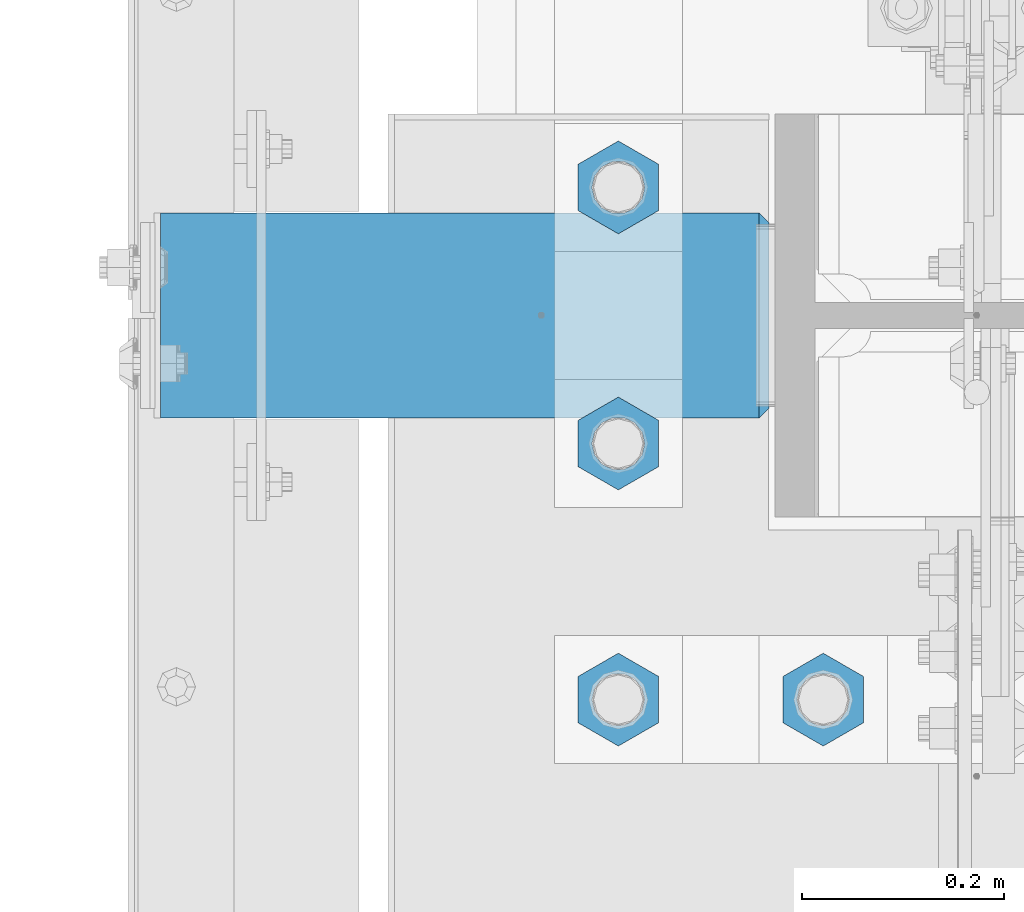
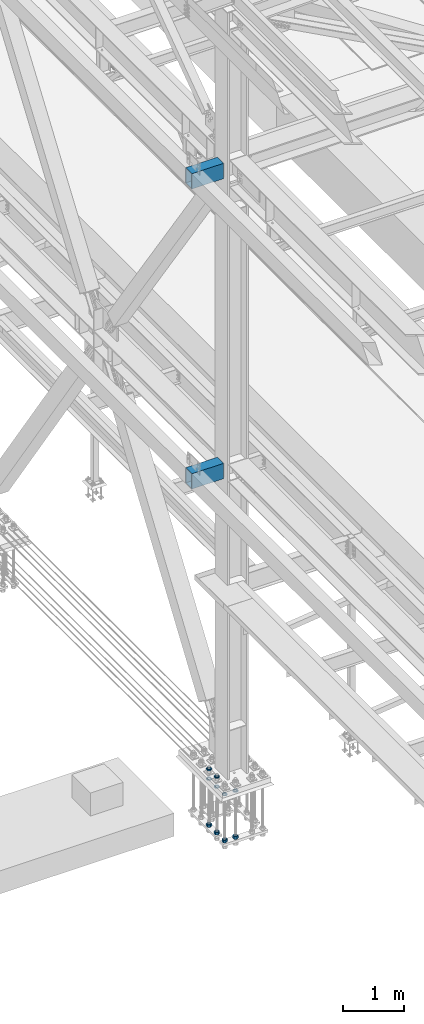
# One storey, part 2193 of 3843: 12 beams, 2 elements without a shape of their own.
"""IFC2X3 building model written with IfcOpenShell, lengths in millimetres."""

from ifc_helpers import new_model, si_unit, frame, origin_with_axes, place, context, subcontext, project, spatial, faceted_brep, material, type_object, element, aggregate, save


model = new_model("IFC2X3")

# Units and contexts
model_context = context("Model", 3, precision=1e-05, world=origin_with_axes())
body_context = subcontext(model_context, "Body", "Model", "MODEL_VIEW")
ifc_project = project(units=[si_unit("LENGTHUNIT", "METRE", prefix="MILLI"), si_unit("AREAUNIT", "SQUARE_METRE"), si_unit("VOLUMEUNIT", "CUBIC_METRE"), si_unit("MASSUNIT", "GRAM", prefix="KILO"), si_unit("TIMEUNIT", "SECOND"), si_unit("PLANEANGLEUNIT", "RADIAN"), si_unit("SOLIDANGLEUNIT", "STERADIAN"), si_unit("THERMODYNAMICTEMPERATUREUNIT", "DEGREE_CELSIUS"), si_unit("LUMINOUSINTENSITYUNIT", "LUMEN")], contexts=[model_context])

# Site, building, storey
site_placement = place(None, origin_with_axes())
site = spatial("IfcSite", under=ifc_project, at=site_placement, CompositionType="ELEMENT")
building_placement = place(site_placement, origin_with_axes())
building = spatial("IfcBuilding", under=site, at=building_placement, Name="Undefined", CompositionType="ELEMENT")
storey_placement = place(building_placement, origin_with_axes())
storey = spatial("IfcBuildingStorey", under=building, at=storey_placement, Name="Undefined", CompositionType="ELEMENT", Elevation=0.0)

# Assembly, beams
assembly_1_placement = place(storey_placement, origin_with_axes())
assembly_1 = element("IfcElementAssembly", 1, at=assembly_1_placement, inside=storey, Name="TEMPLATE", AssemblyPlace="NOTDEFINED", PredefinedType="RIGID_FRAME")
ifc_material_1 = material(Name="STEEL/A572-50")
beam_type_1 = type_object("IfcBeamType", Name="2_HALF_NUT", PredefinedType="NOTDEFINED")
beam_1_placement = place(assembly_1_placement, frame((36423.6, 50177.7, 30060.9), z_axis=(-1.0, 0.0, 0.0), x_axis=(0.0, 0.0, -1.0)))
beam_1 = element("IfcBeam", 2, at=beam_1_placement, type_object=beam_type_1, material=ifc_material_1, Name="NUT", ObjectType="2_HALF_NUT", context=body_context, shape_type="Brep", body=[
    faceted_brep([(0.0, -46.0369987487793, 0.0), (0.0, -23.0184993743896, -39.869213104248), (25.4000000000015, -23.0184993743896, -39.869213104248), (25.4000000000015, -46.0369987487793, 0.0), (0.0, 23.0184993743896, -39.869213104248), (25.4000000000015, 23.0184993743896, -39.869213104248), (0.0, 46.0369987487793, 0.0), (25.4000000000015, 46.0369987487793, 0.0), (0.0, 23.0184993743896, 39.869213104248), (25.4000000000015, 23.0184993743896, 39.869213104248), (0.0, -23.0184993743896, 39.869213104248), (25.4000000000015, -23.0184993743896, 39.869213104248), (0.0, 0.0, 26.1940002441406), (0.0, 11.3650617044477, 23.5999013092805), (25.4000000000015, 11.3650617044477, 23.5999013092805), (25.4000000000015, 0.0, 26.1940002441406), (0.0, 20.4791109456419, 16.3316083006721), (25.4000000000015, 20.4791109456419, 16.3316083006721), (0.0, 25.5370200498292, 5.82867859874386), (25.4000000000015, 25.5370200498292, 5.82867859874386), (0.0, 25.5370200498292, -5.82867859874386), (25.4000000000015, 25.5370200498292, -5.82867859874386), (0.0, 20.4791109456419, -16.3316083006721), (25.4000000000015, 20.4791109456419, -16.3316083006721), (0.0, 11.3650617044477, -23.5999013092805), (25.4000000000015, 11.3650617044477, -23.5999013092805), (0.0, 0.0, -26.1940002441406), (25.4000000000015, 0.0, -26.1940002441406), (0.0, -11.3650617044477, -23.5999013092805), (25.4000000000015, -11.3650617044477, -23.5999013092805), (0.0, -20.4791109456419, -16.3316083006721), (25.4000000000015, -20.4791109456419, -16.3316083006721), (0.0, -25.5370200498292, -5.82867859874386), (25.4000000000015, -25.5370200498292, -5.82867859874386), (0.0, -25.5370200498292, 5.82867859874386), (25.4000000000015, -25.5370200498292, 5.82867859874386), (0.0, -20.4791109456419, 16.3316083006721), (25.4000000000015, -20.4791109456419, 16.3316083006721), (0.0, -11.3650617044477, 23.5999013092805), (25.4000000000015, -11.3650617044477, 23.5999013092805)], [[[0, 1, 2, 3]], [[1, 4, 5, 2]], [[4, 6, 7, 5]], [[6, 8, 9, 7]], [[8, 10, 11, 9]], [[10, 0, 3, 11]], [[12, 13, 14, 15]], [[13, 16, 17, 14]], [[16, 18, 19, 17]], [[18, 20, 21, 19]], [[20, 22, 23, 21]], [[22, 24, 25, 23]], [[24, 26, 27, 25]], [[26, 28, 29, 27]], [[28, 30, 31, 29]], [[30, 32, 33, 31]], [[32, 34, 35, 33]], [[34, 36, 37, 35]], [[36, 38, 39, 37]], [[38, 12, 15, 39]], [[5, 7, 9, 11, 3, 2], [17, 19, 21, 23, 25, 27, 29, 31, 33, 35, 37, 39, 15, 14]], [[10, 8, 6, 4, 1, 0], [38, 36, 34, 32, 30, 28, 26, 24, 22, 20, 18, 16, 13, 12]]]),
])
beam_2_placement = place(assembly_1_placement, frame((36220.4, 50177.7, 30060.9), z_axis=(-1.0, 0.0, 0.0), x_axis=(0.0, 0.0, -1.0)))
beam_2 = element("IfcBeam", 3, at=beam_2_placement, type_object=beam_type_1, material=ifc_material_1, Name="NUT", ObjectType="2_HALF_NUT", context=body_context, shape_type="Brep", body=[
    faceted_brep([(0.0, -46.0369987487793, 0.0), (0.0, -23.0184993743896, -39.869213104248), (25.4000000000015, -23.0184993743896, -39.869213104248), (25.4000000000015, -46.0369987487793, 0.0), (0.0, 23.0184993743896, -39.869213104248), (25.4000000000015, 23.0184993743896, -39.869213104248), (0.0, 46.0369987487793, 0.0), (25.4000000000015, 46.0369987487793, 0.0), (0.0, 23.0184993743896, 39.869213104248), (25.4000000000015, 23.0184993743896, 39.869213104248), (0.0, -23.0184993743896, 39.869213104248), (25.4000000000015, -23.0184993743896, 39.869213104248), (0.0, 0.0, 26.1940002441406), (0.0, 11.3650617044477, 23.5999013092805), (25.4000000000015, 11.3650617044477, 23.5999013092805), (25.4000000000015, 0.0, 26.1940002441406), (0.0, 20.4791109456419, 16.3316083006721), (25.4000000000015, 20.4791109456419, 16.3316083006721), (0.0, 25.5370200498292, 5.82867859874386), (25.4000000000015, 25.5370200498292, 5.82867859874386), (0.0, 25.5370200498292, -5.82867859874386), (25.4000000000015, 25.5370200498292, -5.82867859874386), (0.0, 20.4791109456419, -16.3316083006721), (25.4000000000015, 20.4791109456419, -16.3316083006721), (0.0, 11.3650617044477, -23.5999013092805), (25.4000000000015, 11.3650617044477, -23.5999013092805), (0.0, 0.0, -26.1940002441406), (25.4000000000015, 0.0, -26.1940002441406), (0.0, -11.3650617044477, -23.5999013092805), (25.4000000000015, -11.3650617044477, -23.5999013092805), (0.0, -20.4791109456419, -16.3316083006721), (25.4000000000015, -20.4791109456419, -16.3316083006721), (0.0, -25.5370200498292, -5.82867859874386), (25.4000000000015, -25.5370200498292, -5.82867859874386), (0.0, -25.5370200498292, 5.82867859874386), (25.4000000000015, -25.5370200498292, 5.82867859874386), (0.0, -20.4791109456419, 16.3316083006721), (25.4000000000015, -20.4791109456419, 16.3316083006721), (0.0, -11.3650617044477, 23.5999013092805), (25.4000000000015, -11.3650617044477, 23.5999013092805)], [[[0, 1, 2, 3]], [[1, 4, 5, 2]], [[4, 6, 7, 5]], [[6, 8, 9, 7]], [[8, 10, 11, 9]], [[10, 0, 3, 11]], [[12, 13, 14, 15]], [[13, 16, 17, 14]], [[16, 18, 19, 17]], [[18, 20, 21, 19]], [[20, 22, 23, 21]], [[22, 24, 25, 23]], [[24, 26, 27, 25]], [[26, 28, 29, 27]], [[28, 30, 31, 29]], [[30, 32, 33, 31]], [[32, 34, 35, 33]], [[34, 36, 37, 35]], [[36, 38, 39, 37]], [[38, 12, 15, 39]], [[5, 7, 9, 11, 3, 2], [17, 19, 21, 23, 25, 27, 29, 31, 33, 35, 37, 39, 15, 14]], [[10, 8, 6, 4, 1, 0], [38, 36, 34, 32, 30, 28, 26, 24, 22, 20, 18, 16, 13, 12]]]),
])
beam_3_placement = place(assembly_1_placement, frame((36220.4, 50431.7, 30060.9), z_axis=(-1.0, 0.0, 0.0), x_axis=(0.0, 0.0, -1.0)))
beam_3 = element("IfcBeam", 4, at=beam_3_placement, type_object=beam_type_1, material=ifc_material_1, Name="NUT", ObjectType="2_HALF_NUT", context=body_context, shape_type="Brep", body=[
    faceted_brep([(0.0, -46.0369987487793, 0.0), (0.0, -23.0184993743896, -39.869213104248), (25.4000000000015, -23.0184993743896, -39.869213104248), (25.4000000000015, -46.0369987487793, 0.0), (0.0, 23.0184993743896, -39.869213104248), (25.4000000000015, 23.0184993743896, -39.869213104248), (0.0, 46.0369987487793, 0.0), (25.4000000000015, 46.0369987487793, 0.0), (0.0, 23.0184993743896, 39.869213104248), (25.4000000000015, 23.0184993743896, 39.869213104248), (0.0, -23.0184993743896, 39.869213104248), (25.4000000000015, -23.0184993743896, 39.869213104248), (0.0, 0.0, 26.1940002441406), (0.0, 11.3650617044477, 23.5999013092805), (25.4000000000015, 11.3650617044477, 23.5999013092805), (25.4000000000015, 0.0, 26.1940002441406), (0.0, 20.4791109456419, 16.3316083006721), (25.4000000000015, 20.4791109456419, 16.3316083006721), (0.0, 25.5370200498292, 5.82867859874386), (25.4000000000015, 25.5370200498292, 5.82867859874386), (0.0, 25.5370200498292, -5.82867859874386), (25.4000000000015, 25.5370200498292, -5.82867859874386), (0.0, 20.4791109456419, -16.3316083006721), (25.4000000000015, 20.4791109456419, -16.3316083006721), (0.0, 11.3650617044477, -23.5999013092805), (25.4000000000015, 11.3650617044477, -23.5999013092805), (0.0, 0.0, -26.1940002441406), (25.4000000000015, 0.0, -26.1940002441406), (0.0, -11.3650617044477, -23.5999013092805), (25.4000000000015, -11.3650617044477, -23.5999013092805), (0.0, -20.4791109456419, -16.3316083006721), (25.4000000000015, -20.4791109456419, -16.3316083006721), (0.0, -25.5370200498292, -5.82867859874386), (25.4000000000015, -25.5370200498292, -5.82867859874386), (0.0, -25.5370200498292, 5.82867859874386), (25.4000000000015, -25.5370200498292, 5.82867859874386), (0.0, -20.4791109456419, 16.3316083006721), (25.4000000000015, -20.4791109456419, 16.3316083006721), (0.0, -11.3650617044477, 23.5999013092805), (25.4000000000015, -11.3650617044477, 23.5999013092805)], [[[0, 1, 2, 3]], [[1, 4, 5, 2]], [[4, 6, 7, 5]], [[6, 8, 9, 7]], [[8, 10, 11, 9]], [[10, 0, 3, 11]], [[12, 13, 14, 15]], [[13, 16, 17, 14]], [[16, 18, 19, 17]], [[18, 20, 21, 19]], [[20, 22, 23, 21]], [[22, 24, 25, 23]], [[24, 26, 27, 25]], [[26, 28, 29, 27]], [[28, 30, 31, 29]], [[30, 32, 33, 31]], [[32, 34, 35, 33]], [[34, 36, 37, 35]], [[36, 38, 39, 37]], [[38, 12, 15, 39]], [[5, 7, 9, 11, 3, 2], [17, 19, 21, 23, 25, 27, 29, 31, 33, 35, 37, 39, 15, 14]], [[10, 8, 6, 4, 1, 0], [38, 36, 34, 32, 30, 28, 26, 24, 22, 20, 18, 16, 13, 12]]]),
])
beam_4_placement = place(assembly_1_placement, frame((36220.4, 50685.7, 30060.9), z_axis=(-1.0, 0.0, 0.0), x_axis=(0.0, 0.0, -1.0)))
beam_4 = element("IfcBeam", 5, at=beam_4_placement, type_object=beam_type_1, material=ifc_material_1, Name="NUT", ObjectType="2_HALF_NUT", context=body_context, shape_type="Brep", body=[
    faceted_brep([(0.0, -46.0369987487793, 0.0), (0.0, -23.0184993743896, -39.869213104248), (25.4000000000015, -23.0184993743896, -39.869213104248), (25.4000000000015, -46.0369987487793, 0.0), (0.0, 23.0184993743896, -39.869213104248), (25.4000000000015, 23.0184993743896, -39.869213104248), (0.0, 46.0369987487793, 0.0), (25.4000000000015, 46.0369987487793, 0.0), (0.0, 23.0184993743896, 39.869213104248), (25.4000000000015, 23.0184993743896, 39.869213104248), (0.0, -23.0184993743896, 39.869213104248), (25.4000000000015, -23.0184993743896, 39.869213104248), (0.0, 0.0, 26.1940002441406), (0.0, 11.3650617044477, 23.5999013092805), (25.4000000000015, 11.3650617044477, 23.5999013092805), (25.4000000000015, 0.0, 26.1940002441406), (0.0, 20.4791109456419, 16.3316083006721), (25.4000000000015, 20.4791109456419, 16.3316083006721), (0.0, 25.5370200498292, 5.82867859874386), (25.4000000000015, 25.5370200498292, 5.82867859874386), (0.0, 25.5370200498292, -5.82867859874386), (25.4000000000015, 25.5370200498292, -5.82867859874386), (0.0, 20.4791109456419, -16.3316083006721), (25.4000000000015, 20.4791109456419, -16.3316083006721), (0.0, 11.3650617044477, -23.5999013092805), (25.4000000000015, 11.3650617044477, -23.5999013092805), (0.0, 0.0, -26.1940002441406), (25.4000000000015, 0.0, -26.1940002441406), (0.0, -11.3650617044477, -23.5999013092805), (25.4000000000015, -11.3650617044477, -23.5999013092805), (0.0, -20.4791109456419, -16.3316083006721), (25.4000000000015, -20.4791109456419, -16.3316083006721), (0.0, -25.5370200498292, -5.82867859874386), (25.4000000000015, -25.5370200498292, -5.82867859874386), (0.0, -25.5370200498292, 5.82867859874386), (25.4000000000015, -25.5370200498292, 5.82867859874386), (0.0, -20.4791109456419, 16.3316083006721), (25.4000000000015, -20.4791109456419, 16.3316083006721), (0.0, -11.3650617044477, 23.5999013092805), (25.4000000000015, -11.3650617044477, 23.5999013092805)], [[[0, 1, 2, 3]], [[1, 4, 5, 2]], [[4, 6, 7, 5]], [[6, 8, 9, 7]], [[8, 10, 11, 9]], [[10, 0, 3, 11]], [[12, 13, 14, 15]], [[13, 16, 17, 14]], [[16, 18, 19, 17]], [[18, 20, 21, 19]], [[20, 22, 23, 21]], [[22, 24, 25, 23]], [[24, 26, 27, 25]], [[26, 28, 29, 27]], [[28, 30, 31, 29]], [[30, 32, 33, 31]], [[32, 34, 35, 33]], [[34, 36, 37, 35]], [[36, 38, 39, 37]], [[38, 12, 15, 39]], [[5, 7, 9, 11, 3, 2], [17, 19, 21, 23, 25, 27, 29, 31, 33, 35, 37, 39, 15, 14]], [[10, 8, 6, 4, 1, 0], [38, 36, 34, 32, 30, 28, 26, 24, 22, 20, 18, 16, 13, 12]]]),
])
beam_5_placement = place(assembly_1_placement, frame((36220.4, 50685.7, 30257.75), z_axis=(1.0, 0.0, 0.0), x_axis=(0.0, 0.0, -1.0)))
beam_5 = element("IfcBeam", 6, at=beam_5_placement, type_object=beam_type_1, material=ifc_material_1, Name="NUT", ObjectType="2_HALF_NUT", context=body_context, shape_type="Brep", body=[
    faceted_brep([(0.0, -46.0369987487793, 0.0), (0.0, -23.0184993743896, -39.869213104248), (25.4000000000015, -23.0184993743896, -39.869213104248), (25.4000000000015, -46.0369987487793, 0.0), (0.0, 23.0184993743896, -39.869213104248), (25.4000000000015, 23.0184993743896, -39.869213104248), (0.0, 46.0369987487793, 0.0), (25.4000000000015, 46.0369987487793, 0.0), (0.0, 23.0184993743896, 39.869213104248), (25.4000000000015, 23.0184993743896, 39.869213104248), (0.0, -23.0184993743896, 39.869213104248), (25.4000000000015, -23.0184993743896, 39.869213104248), (0.0, 0.0, 26.1940002441406), (0.0, 11.3650617044477, 23.5999013092805), (25.4000000000015, 11.3650617044477, 23.5999013092805), (25.4000000000015, 0.0, 26.1940002441406), (0.0, 20.4791109456419, 16.3316083006721), (25.4000000000015, 20.4791109456419, 16.3316083006721), (0.0, 25.5370200498292, 5.82867859874386), (25.4000000000015, 25.5370200498292, 5.82867859874386), (0.0, 25.5370200498292, -5.82867859874386), (25.4000000000015, 25.5370200498292, -5.82867859874386), (0.0, 20.4791109456419, -16.3316083006721), (25.4000000000015, 20.4791109456419, -16.3316083006721), (0.0, 11.3650617044477, -23.5999013092805), (25.4000000000015, 11.3650617044477, -23.5999013092805), (0.0, 0.0, -26.1940002441406), (25.4000000000015, 0.0, -26.1940002441406), (0.0, -11.3650617044477, -23.5999013092805), (25.4000000000015, -11.3650617044477, -23.5999013092805), (0.0, -20.4791109456419, -16.3316083006721), (25.4000000000015, -20.4791109456419, -16.3316083006721), (0.0, -25.5370200498292, -5.82867859874386), (25.4000000000015, -25.5370200498292, -5.82867859874386), (0.0, -25.5370200498292, 5.82867859874386), (25.4000000000015, -25.5370200498292, 5.82867859874386), (0.0, -20.4791109456419, 16.3316083006721), (25.4000000000015, -20.4791109456419, 16.3316083006721), (0.0, -11.3650617044477, 23.5999013092805), (25.4000000000015, -11.3650617044477, 23.5999013092805)], [[[0, 1, 2, 3]], [[1, 4, 5, 2]], [[4, 6, 7, 5]], [[6, 8, 9, 7]], [[8, 10, 11, 9]], [[10, 0, 3, 11]], [[12, 13, 14, 15]], [[13, 16, 17, 14]], [[16, 18, 19, 17]], [[18, 20, 21, 19]], [[20, 22, 23, 21]], [[22, 24, 25, 23]], [[24, 26, 27, 25]], [[26, 28, 29, 27]], [[28, 30, 31, 29]], [[30, 32, 33, 31]], [[32, 34, 35, 33]], [[34, 36, 37, 35]], [[36, 38, 39, 37]], [[38, 12, 15, 39]], [[5, 7, 9, 11, 3, 2], [17, 19, 21, 23, 25, 27, 29, 31, 33, 35, 37, 39, 15, 14]], [[10, 8, 6, 4, 1, 0], [38, 36, 34, 32, 30, 28, 26, 24, 22, 20, 18, 16, 13, 12]]]),
])
beam_6_placement = place(assembly_1_placement, frame((36220.4, 50431.7, 30257.75), z_axis=(1.0, 0.0, 0.0), x_axis=(0.0, 0.0, -1.0)))
beam_6 = element("IfcBeam", 7, at=beam_6_placement, type_object=beam_type_1, material=ifc_material_1, Name="NUT", ObjectType="2_HALF_NUT", context=body_context, shape_type="Brep", body=[
    faceted_brep([(0.0, -46.0369987487793, 0.0), (0.0, -23.0184993743896, -39.869213104248), (25.4000000000015, -23.0184993743896, -39.869213104248), (25.4000000000015, -46.0369987487793, 0.0), (0.0, 23.0184993743896, -39.869213104248), (25.4000000000015, 23.0184993743896, -39.869213104248), (0.0, 46.0369987487793, 0.0), (25.4000000000015, 46.0369987487793, 0.0), (0.0, 23.0184993743896, 39.869213104248), (25.4000000000015, 23.0184993743896, 39.869213104248), (0.0, -23.0184993743896, 39.869213104248), (25.4000000000015, -23.0184993743896, 39.869213104248), (0.0, 0.0, 26.1940002441406), (0.0, 11.3650617044477, 23.5999013092805), (25.4000000000015, 11.3650617044477, 23.5999013092805), (25.4000000000015, 0.0, 26.1940002441406), (0.0, 20.4791109456419, 16.3316083006721), (25.4000000000015, 20.4791109456419, 16.3316083006721), (0.0, 25.5370200498292, 5.82867859874386), (25.4000000000015, 25.5370200498292, 5.82867859874386), (0.0, 25.5370200498292, -5.82867859874386), (25.4000000000015, 25.5370200498292, -5.82867859874386), (0.0, 20.4791109456419, -16.3316083006721), (25.4000000000015, 20.4791109456419, -16.3316083006721), (0.0, 11.3650617044477, -23.5999013092805), (25.4000000000015, 11.3650617044477, -23.5999013092805), (0.0, 0.0, -26.1940002441406), (25.4000000000015, 0.0, -26.1940002441406), (0.0, -11.3650617044477, -23.5999013092805), (25.4000000000015, -11.3650617044477, -23.5999013092805), (0.0, -20.4791109456419, -16.3316083006721), (25.4000000000015, -20.4791109456419, -16.3316083006721), (0.0, -25.5370200498292, -5.82867859874386), (25.4000000000015, -25.5370200498292, -5.82867859874386), (0.0, -25.5370200498292, 5.82867859874386), (25.4000000000015, -25.5370200498292, 5.82867859874386), (0.0, -20.4791109456419, 16.3316083006721), (25.4000000000015, -20.4791109456419, 16.3316083006721), (0.0, -11.3650617044477, 23.5999013092805), (25.4000000000015, -11.3650617044477, 23.5999013092805)], [[[0, 1, 2, 3]], [[1, 4, 5, 2]], [[4, 6, 7, 5]], [[6, 8, 9, 7]], [[8, 10, 11, 9]], [[10, 0, 3, 11]], [[12, 13, 14, 15]], [[13, 16, 17, 14]], [[16, 18, 19, 17]], [[18, 20, 21, 19]], [[20, 22, 23, 21]], [[22, 24, 25, 23]], [[24, 26, 27, 25]], [[26, 28, 29, 27]], [[28, 30, 31, 29]], [[30, 32, 33, 31]], [[32, 34, 35, 33]], [[34, 36, 37, 35]], [[36, 38, 39, 37]], [[38, 12, 15, 39]], [[5, 7, 9, 11, 3, 2], [17, 19, 21, 23, 25, 27, 29, 31, 33, 35, 37, 39, 15, 14]], [[10, 8, 6, 4, 1, 0], [38, 36, 34, 32, 30, 28, 26, 24, 22, 20, 18, 16, 13, 12]]]),
])
beam_type_2 = type_object("IfcBeamType", Name="2_HEAVY_HEX_NUT", PredefinedType="NOTDEFINED")
beam_7_placement = place(assembly_1_placement, frame((36423.6, 50177.7, 29159.2), z_axis=(1.0, 0.0, 0.0), x_axis=(0.0, 0.0, -1.0)))
beam_7 = element("IfcBeam", 8, at=beam_7_placement, type_object=beam_type_2, material=ifc_material_1, Name="NUT", ObjectType="2_HEAVY_HEX_NUT", context=body_context, shape_type="Brep", body=[
    faceted_brep([(0.0, -46.0369987487793, 0.0), (0.0, -23.0184993743896, -39.869213104248), (50.7999999999993, -23.0184993743896, -39.869213104248), (50.7999999999993, -46.0369987487793, 0.0), (0.0, 23.0184993743896, -39.869213104248), (50.7999999999993, 23.0184993743896, -39.869213104248), (0.0, 46.0369987487793, 0.0), (50.7999999999993, 46.0369987487793, 0.0), (0.0, 23.0184993743896, 39.869213104248), (50.7999999999993, 23.0184993743896, 39.869213104248), (0.0, -23.0184993743896, 39.869213104248), (50.7999999999993, -23.0184993743896, 39.869213104248), (0.0, 0.0, 26.1940002441406), (0.0, 11.3650617044477, 23.5999013092805), (50.7999999999993, 11.3650617044477, 23.5999013092805), (50.7999999999993, 0.0, 26.1940002441406), (0.0, 20.4791109456419, 16.3316083006721), (50.7999999999993, 20.4791109456419, 16.3316083006721), (0.0, 25.5370200498292, 5.82867859874386), (50.7999999999993, 25.5370200498292, 5.82867859874386), (0.0, 25.5370200498292, -5.82867859874386), (50.7999999999993, 25.5370200498292, -5.82867859874386), (0.0, 20.4791109456419, -16.3316083006721), (50.7999999999993, 20.4791109456419, -16.3316083006721), (0.0, 11.3650617044477, -23.5999013092805), (50.7999999999993, 11.3650617044477, -23.5999013092805), (0.0, 0.0, -26.1940002441406), (50.7999999999993, 0.0, -26.1940002441406), (0.0, -11.3650617044477, -23.5999013092805), (50.7999999999993, -11.3650617044477, -23.5999013092805), (0.0, -20.4791109456419, -16.3316083006721), (50.7999999999993, -20.4791109456419, -16.3316083006721), (0.0, -25.5370200498292, -5.82867859874386), (50.7999999999993, -25.5370200498292, -5.82867859874386), (0.0, -25.5370200498292, 5.82867859874386), (50.7999999999993, -25.5370200498292, 5.82867859874386), (0.0, -20.4791109456419, 16.3316083006721), (50.7999999999993, -20.4791109456419, 16.3316083006721), (0.0, -11.3650617044477, 23.5999013092805), (50.7999999999993, -11.3650617044477, 23.5999013092805)], [[[0, 1, 2, 3]], [[1, 4, 5, 2]], [[4, 6, 7, 5]], [[6, 8, 9, 7]], [[8, 10, 11, 9]], [[10, 0, 3, 11]], [[12, 13, 14, 15]], [[13, 16, 17, 14]], [[16, 18, 19, 17]], [[18, 20, 21, 19]], [[20, 22, 23, 21]], [[22, 24, 25, 23]], [[24, 26, 27, 25]], [[26, 28, 29, 27]], [[28, 30, 31, 29]], [[30, 32, 33, 31]], [[32, 34, 35, 33]], [[34, 36, 37, 35]], [[36, 38, 39, 37]], [[38, 12, 15, 39]], [[5, 7, 9, 11, 3, 2], [17, 19, 21, 23, 25, 27, 29, 31, 33, 35, 37, 39, 15, 14]], [[10, 8, 6, 4, 1, 0], [38, 36, 34, 32, 30, 28, 26, 24, 22, 20, 18, 16, 13, 12]]]),
])
beam_8_placement = place(assembly_1_placement, frame((36220.4, 50177.7, 29159.2), z_axis=(1.0, 0.0, 0.0), x_axis=(0.0, 0.0, -1.0)))
beam_8 = element("IfcBeam", 9, at=beam_8_placement, type_object=beam_type_2, material=ifc_material_1, Name="NUT", ObjectType="2_HEAVY_HEX_NUT", context=body_context, shape_type="Brep", body=[
    faceted_brep([(0.0, -46.0369987487793, 0.0), (0.0, -23.0184993743896, -39.869213104248), (50.7999999999993, -23.0184993743896, -39.869213104248), (50.7999999999993, -46.0369987487793, 0.0), (0.0, 23.0184993743896, -39.869213104248), (50.7999999999993, 23.0184993743896, -39.869213104248), (0.0, 46.0369987487793, 0.0), (50.7999999999993, 46.0369987487793, 0.0), (0.0, 23.0184993743896, 39.869213104248), (50.7999999999993, 23.0184993743896, 39.869213104248), (0.0, -23.0184993743896, 39.869213104248), (50.7999999999993, -23.0184993743896, 39.869213104248), (0.0, 0.0, 26.1940002441406), (0.0, 11.3650617044477, 23.5999013092805), (50.7999999999993, 11.3650617044477, 23.5999013092805), (50.7999999999993, 0.0, 26.1940002441406), (0.0, 20.4791109456419, 16.3316083006721), (50.7999999999993, 20.4791109456419, 16.3316083006721), (0.0, 25.5370200498292, 5.82867859874386), (50.7999999999993, 25.5370200498292, 5.82867859874386), (0.0, 25.5370200498292, -5.82867859874386), (50.7999999999993, 25.5370200498292, -5.82867859874386), (0.0, 20.4791109456419, -16.3316083006721), (50.7999999999993, 20.4791109456419, -16.3316083006721), (0.0, 11.3650617044477, -23.5999013092805), (50.7999999999993, 11.3650617044477, -23.5999013092805), (0.0, 0.0, -26.1940002441406), (50.7999999999993, 0.0, -26.1940002441406), (0.0, -11.3650617044477, -23.5999013092805), (50.7999999999993, -11.3650617044477, -23.5999013092805), (0.0, -20.4791109456419, -16.3316083006721), (50.7999999999993, -20.4791109456419, -16.3316083006721), (0.0, -25.5370200498292, -5.82867859874386), (50.7999999999993, -25.5370200498292, -5.82867859874386), (0.0, -25.5370200498292, 5.82867859874386), (50.7999999999993, -25.5370200498292, 5.82867859874386), (0.0, -20.4791109456419, 16.3316083006721), (50.7999999999993, -20.4791109456419, 16.3316083006721), (0.0, -11.3650617044477, 23.5999013092805), (50.7999999999993, -11.3650617044477, 23.5999013092805)], [[[0, 1, 2, 3]], [[1, 4, 5, 2]], [[4, 6, 7, 5]], [[6, 8, 9, 7]], [[8, 10, 11, 9]], [[10, 0, 3, 11]], [[12, 13, 14, 15]], [[13, 16, 17, 14]], [[16, 18, 19, 17]], [[18, 20, 21, 19]], [[20, 22, 23, 21]], [[22, 24, 25, 23]], [[24, 26, 27, 25]], [[26, 28, 29, 27]], [[28, 30, 31, 29]], [[30, 32, 33, 31]], [[32, 34, 35, 33]], [[34, 36, 37, 35]], [[36, 38, 39, 37]], [[38, 12, 15, 39]], [[5, 7, 9, 11, 3, 2], [17, 19, 21, 23, 25, 27, 29, 31, 33, 35, 37, 39, 15, 14]], [[10, 8, 6, 4, 1, 0], [38, 36, 34, 32, 30, 28, 26, 24, 22, 20, 18, 16, 13, 12]]]),
])
beam_9_placement = place(assembly_1_placement, frame((36220.4, 50431.7, 29159.2), z_axis=(1.0, 0.0, 0.0), x_axis=(0.0, 0.0, -1.0)))
beam_9 = element("IfcBeam", 10, at=beam_9_placement, type_object=beam_type_2, material=ifc_material_1, Name="NUT", ObjectType="2_HEAVY_HEX_NUT", context=body_context, shape_type="Brep", body=[
    faceted_brep([(0.0, -46.0369987487793, 0.0), (0.0, -23.0184993743896, -39.869213104248), (50.7999999999993, -23.0184993743896, -39.869213104248), (50.7999999999993, -46.0369987487793, 0.0), (0.0, 23.0184993743896, -39.869213104248), (50.7999999999993, 23.0184993743896, -39.869213104248), (0.0, 46.0369987487793, 0.0), (50.7999999999993, 46.0369987487793, 0.0), (0.0, 23.0184993743896, 39.869213104248), (50.7999999999993, 23.0184993743896, 39.869213104248), (0.0, -23.0184993743896, 39.869213104248), (50.7999999999993, -23.0184993743896, 39.869213104248), (0.0, 0.0, 26.1940002441406), (0.0, 11.3650617044477, 23.5999013092805), (50.7999999999993, 11.3650617044477, 23.5999013092805), (50.7999999999993, 0.0, 26.1940002441406), (0.0, 20.4791109456419, 16.3316083006721), (50.7999999999993, 20.4791109456419, 16.3316083006721), (0.0, 25.5370200498292, 5.82867859874386), (50.7999999999993, 25.5370200498292, 5.82867859874386), (0.0, 25.5370200498292, -5.82867859874386), (50.7999999999993, 25.5370200498292, -5.82867859874386), (0.0, 20.4791109456419, -16.3316083006721), (50.7999999999993, 20.4791109456419, -16.3316083006721), (0.0, 11.3650617044477, -23.5999013092805), (50.7999999999993, 11.3650617044477, -23.5999013092805), (0.0, 0.0, -26.1940002441406), (50.7999999999993, 0.0, -26.1940002441406), (0.0, -11.3650617044477, -23.5999013092805), (50.7999999999993, -11.3650617044477, -23.5999013092805), (0.0, -20.4791109456419, -16.3316083006721), (50.7999999999993, -20.4791109456419, -16.3316083006721), (0.0, -25.5370200498292, -5.82867859874386), (50.7999999999993, -25.5370200498292, -5.82867859874386), (0.0, -25.5370200498292, 5.82867859874386), (50.7999999999993, -25.5370200498292, 5.82867859874386), (0.0, -20.4791109456419, 16.3316083006721), (50.7999999999993, -20.4791109456419, 16.3316083006721), (0.0, -11.3650617044477, 23.5999013092805), (50.7999999999993, -11.3650617044477, 23.5999013092805)], [[[0, 1, 2, 3]], [[1, 4, 5, 2]], [[4, 6, 7, 5]], [[6, 8, 9, 7]], [[8, 10, 11, 9]], [[10, 0, 3, 11]], [[12, 13, 14, 15]], [[13, 16, 17, 14]], [[16, 18, 19, 17]], [[18, 20, 21, 19]], [[20, 22, 23, 21]], [[22, 24, 25, 23]], [[24, 26, 27, 25]], [[26, 28, 29, 27]], [[28, 30, 31, 29]], [[30, 32, 33, 31]], [[32, 34, 35, 33]], [[34, 36, 37, 35]], [[36, 38, 39, 37]], [[38, 12, 15, 39]], [[5, 7, 9, 11, 3, 2], [17, 19, 21, 23, 25, 27, 29, 31, 33, 35, 37, 39, 15, 14]], [[10, 8, 6, 4, 1, 0], [38, 36, 34, 32, 30, 28, 26, 24, 22, 20, 18, 16, 13, 12]]]),
])
beam_10_placement = place(assembly_1_placement, frame((36220.4, 50685.7, 29159.2), z_axis=(1.0, 0.0, 0.0), x_axis=(0.0, 0.0, -1.0)))
beam_10 = element("IfcBeam", 11, at=beam_10_placement, type_object=beam_type_2, material=ifc_material_1, Name="NUT", ObjectType="2_HEAVY_HEX_NUT", context=body_context, shape_type="Brep", body=[
    faceted_brep([(0.0, -46.0369987487793, 0.0), (0.0, -23.0184993743896, -39.869213104248), (50.7999999999993, -23.0184993743896, -39.869213104248), (50.7999999999993, -46.0369987487793, 0.0), (0.0, 23.0184993743896, -39.869213104248), (50.7999999999993, 23.0184993743896, -39.869213104248), (0.0, 46.0369987487793, 0.0), (50.7999999999993, 46.0369987487793, 0.0), (0.0, 23.0184993743896, 39.869213104248), (50.7999999999993, 23.0184993743896, 39.869213104248), (0.0, -23.0184993743896, 39.869213104248), (50.7999999999993, -23.0184993743896, 39.869213104248), (0.0, 0.0, 26.1940002441406), (0.0, 11.3650617044477, 23.5999013092805), (50.7999999999993, 11.3650617044477, 23.5999013092805), (50.7999999999993, 0.0, 26.1940002441406), (0.0, 20.4791109456419, 16.3316083006721), (50.7999999999993, 20.4791109456419, 16.3316083006721), (0.0, 25.5370200498292, 5.82867859874386), (50.7999999999993, 25.5370200498292, 5.82867859874386), (0.0, 25.5370200498292, -5.82867859874386), (50.7999999999993, 25.5370200498292, -5.82867859874386), (0.0, 20.4791109456419, -16.3316083006721), (50.7999999999993, 20.4791109456419, -16.3316083006721), (0.0, 11.3650617044477, -23.5999013092805), (50.7999999999993, 11.3650617044477, -23.5999013092805), (0.0, 0.0, -26.1940002441406), (50.7999999999993, 0.0, -26.1940002441406), (0.0, -11.3650617044477, -23.5999013092805), (50.7999999999993, -11.3650617044477, -23.5999013092805), (0.0, -20.4791109456419, -16.3316083006721), (50.7999999999993, -20.4791109456419, -16.3316083006721), (0.0, -25.5370200498292, -5.82867859874386), (50.7999999999993, -25.5370200498292, -5.82867859874386), (0.0, -25.5370200498292, 5.82867859874386), (50.7999999999993, -25.5370200498292, 5.82867859874386), (0.0, -20.4791109456419, 16.3316083006721), (50.7999999999993, -20.4791109456419, 16.3316083006721), (0.0, -11.3650617044477, 23.5999013092805), (50.7999999999993, -11.3650617044477, 23.5999013092805)], [[[0, 1, 2, 3]], [[1, 4, 5, 2]], [[4, 6, 7, 5]], [[6, 8, 9, 7]], [[8, 10, 11, 9]], [[10, 0, 3, 11]], [[12, 13, 14, 15]], [[13, 16, 17, 14]], [[16, 18, 19, 17]], [[18, 20, 21, 19]], [[20, 22, 23, 21]], [[22, 24, 25, 23]], [[24, 26, 27, 25]], [[26, 28, 29, 27]], [[28, 30, 31, 29]], [[30, 32, 33, 31]], [[32, 34, 35, 33]], [[34, 36, 37, 35]], [[36, 38, 39, 37]], [[38, 12, 15, 39]], [[5, 7, 9, 11, 3, 2], [17, 19, 21, 23, 25, 27, 29, 31, 33, 35, 37, 39, 15, 14]], [[10, 8, 6, 4, 1, 0], [38, 36, 34, 32, 30, 28, 26, 24, 22, 20, 18, 16, 13, 12]]]),
])
aggregate(assembly_1, [beam_7, beam_8, beam_9, beam_10, beam_1, beam_2, beam_3, beam_4, beam_5, beam_6])

assembly_2_placement = place(storey_placement, origin_with_axes())
assembly_2 = element("IfcElementAssembly", 12, at=assembly_2_placement, inside=storey, Name="COLUMN", AssemblyPlace="NOTDEFINED", PredefinedType="RIGID_FRAME")
ifc_material_2 = material()
beam_type_3 = type_object("IfcBeamType", Name="HSS12X8X3/8", PredefinedType="NOTDEFINED")
beam_11_placement = place(assembly_2_placement, frame((35760.025, 50558.7, 42214.8), z_axis=(0.0, 0.0, 1.0), x_axis=(1.0, 0.0, 0.0)))
beam_11 = element("IfcBeam", 13, at=beam_11_placement, type_object=beam_type_3, material=ifc_material_2, Name="GIRT", ObjectType="HSS12X8X3/8", context=body_context, shape_type="Brep", body=[
    faceted_brep([(609.600000000006, 92.0749999999971, 142.875), (609.600000000006, 92.0749999999971, -142.875), (600.075000000004, 101.600000000006, -152.400000000001), (600.075000000004, 101.600000000006, 152.400000000001), (609.600000000006, -92.0749999999971, -142.875), (600.075000000004, -101.600000000006, -152.400000000001), (609.600000000006, -92.0749999999971, 142.875), (600.075000000004, -101.600000000006, 152.400000000001), (6.35000000002037, 92.0749999999971, 142.875), (6.35000000002037, 92.0749999999971, -142.875), (6.35000000002037, -92.0749999999971, 142.875), (6.35000000002037, -92.0749999999971, -142.875), (6.35000000002037, -101.600000000006, -152.400000000001), (6.35000000002037, -101.600000000006, 152.400000000001), (6.35000000002037, 101.600000000006, 152.400000000001), (6.35000000002037, 101.600000000006, -152.400000000001)], [[[0, 1, 2, 3]], [[4, 5, 2, 1]], [[6, 7, 5, 4]], [[8, 9, 1, 0]], [[10, 8, 0, 6]], [[11, 10, 6, 4]], [[9, 11, 4, 1]], [[12, 13, 14, 15], [8, 10, 11, 9]], [[15, 14, 3, 2]], [[12, 15, 2, 5]], [[13, 12, 5, 7]], [[14, 13, 7, 3]], [[0, 3, 7, 6]]]),
])
beam_12_placement = place(assembly_2_placement, frame((35760.025, 50558.7, 36252.15), z_axis=(0.0, 0.0, 1.0), x_axis=(1.0, 0.0, 0.0)))
beam_12 = element("IfcBeam", 14, at=beam_12_placement, type_object=beam_type_3, material=ifc_material_2, Name="BEAM", ObjectType="HSS12X8X3/8", context=body_context, shape_type="Brep", body=[
    faceted_brep([(609.600000000006, 92.0749999999971, 142.875), (609.600000000006, 92.0749999999971, -142.875), (600.075000000004, 101.600000000006, -152.400000000001), (600.075000000004, 101.600000000006, 152.400000000001), (609.600000000006, -92.0749999999971, -142.875), (600.075000000004, -101.600000000006, -152.400000000001), (609.600000000006, -92.0749999999971, 142.875), (600.075000000004, -101.600000000006, 152.400000000001), (6.35000000002037, 92.0749999999971, 142.875), (6.35000000002037, 92.0749999999971, -142.875), (6.35000000002037, -92.0749999999971, 142.875), (6.35000000002037, -92.0749999999971, -142.875), (6.35000000002037, -101.600000000006, -152.400000000001), (6.35000000002037, -101.600000000006, 152.400000000001), (6.35000000002037, 101.600000000006, 152.400000000001), (6.35000000002037, 101.600000000006, -152.400000000001)], [[[0, 1, 2, 3]], [[4, 5, 2, 1]], [[6, 7, 5, 4]], [[8, 9, 1, 0]], [[10, 8, 0, 6]], [[11, 10, 6, 4]], [[9, 11, 4, 1]], [[12, 13, 14, 15], [8, 10, 11, 9]], [[15, 14, 3, 2]], [[12, 15, 2, 5]], [[13, 12, 5, 7]], [[14, 13, 7, 3]], [[0, 3, 7, 6]]]),
])
aggregate(assembly_2, [beam_11, beam_12])

save(model, "model.ifc")
